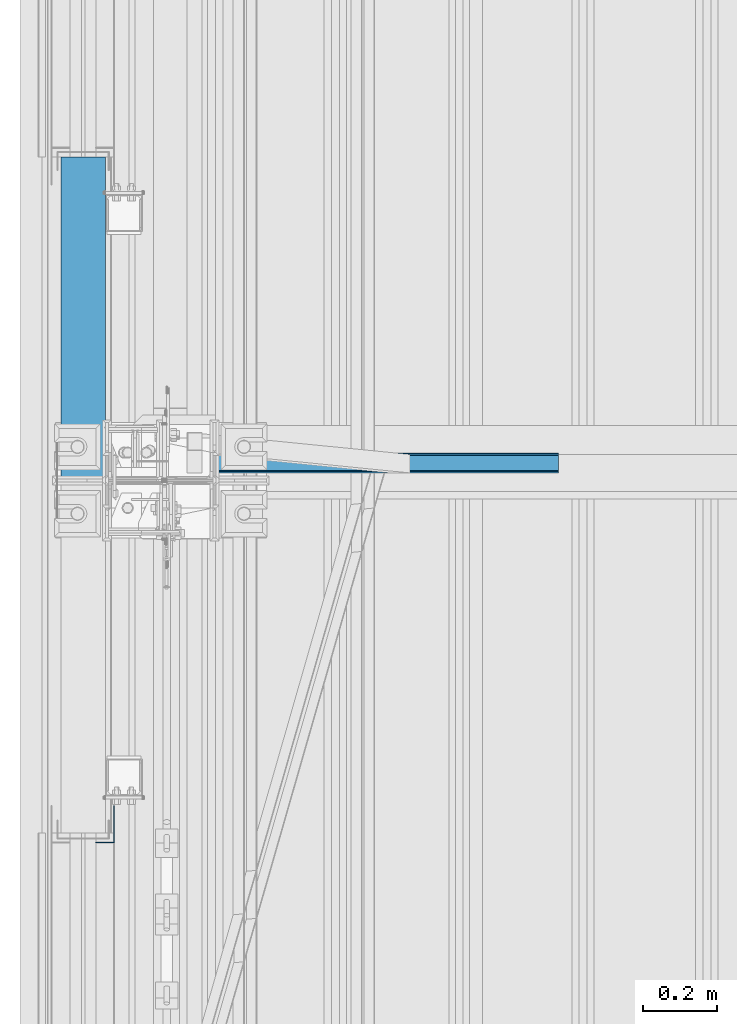
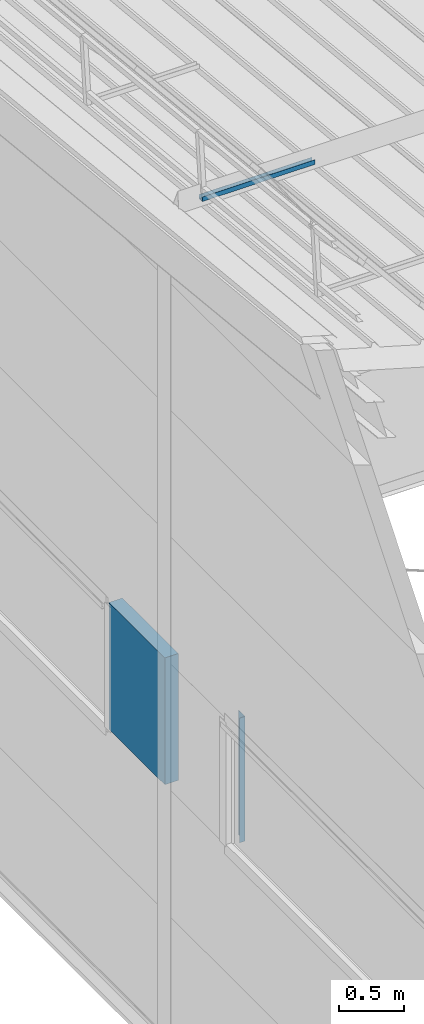
# One storey, part 47 of 709: 3 beams, 3 elements without a shape of their own.
"""IFC4 building model written with IfcOpenShell, lengths in millimetres."""

from ifc_helpers import new_model, si_unit, direction, frame, origin_with_axes, place, context, subcontext, project, spatial, line, indexed_curve, outline, extrude, material, element, aggregate, save


model = new_model("IFC4")

# Units and contexts
model_context = context("Model", 3, precision=0.2, world=origin_with_axes(), true_north=direction((0.0, 1.0)))
body_context = subcontext(model_context, "Body", "Model", "MODEL_VIEW")
ifc_project = project(units=[si_unit("LENGTHUNIT", "METRE", prefix="MILLI"), si_unit("AREAUNIT", "SQUARE_METRE"), si_unit("VOLUMEUNIT", "CUBIC_METRE"), si_unit("MASSUNIT", "GRAM", prefix="KILO"), si_unit("TIMEUNIT", "SECOND"), si_unit("PLANEANGLEUNIT", "RADIAN"), si_unit("SOLIDANGLEUNIT", "STERADIAN"), si_unit("THERMODYNAMICTEMPERATUREUNIT", "DEGREE_CELSIUS"), si_unit("LUMINOUSINTENSITYUNIT", "LUMEN")], contexts=[model_context])

# Site, building, storey
site_placement = place(None, origin_with_axes())
site = spatial("IfcSite", under=ifc_project, at=site_placement, CompositionType="ELEMENT")
building_placement = place(site_placement, origin_with_axes())
building = spatial("IfcBuilding", under=site, at=building_placement, Name="Undefined", CompositionType="ELEMENT")
storey_placement = place(building_placement, origin_with_axes())
storey = spatial("IfcBuildingStorey", under=building, at=storey_placement, Name="Undefined", CompositionType="ELEMENT", Elevation=0.0)

# Assembly, beam
assembly_1_placement = place(storey_placement, frame((220.0, 16546.76675, 8045.59294), z_axis=(0.0, 0.099503719, 0.9950371902), x_axis=(1.0, 0.0, 0.0)))
assembly_1 = element("IfcElementAssembly", 1, at=assembly_1_placement, inside=storey)
ifc_material_1 = material(Name="Steel_Undefined", Category="STEEL")
beam_1_placement = place(assembly_1_placement, origin_with_axes())
beam_1 = element("IfcBeam", 2, at=beam_1_placement, material=ifc_material_1, ObjectType="601", context=body_context, shape_type="SolidModel", body=[
    extrude(outline(indexed_curve([(-20.0, -25.0), (20.0, -25.0), (20.0, -22.5), (-17.5, -22.5), (-17.5, 22.5), (20.0, 22.5), (20.0, 25.0), (-20.0, 25.0)], segments=[line(1, 2, 3, 4, 5, 6, 7, 8, 1)])), frame((0.0, 0.0, 0.0), z_axis=(-1.0, 0.0, 0.0), x_axis=(0.0, 0.0, 1.0)), (0.0, 0.0, -1.0), 1000.0),
])
aggregate(assembly_1, [beam_1])

assembly_2_placement = place(storey_placement, frame((-60.0, 16510.0, 3275.0), z_axis=(0.0, 0.0, -1.0), x_axis=(0.0, 1.0, 0.0)))
assembly_2 = element("IfcElementAssembly", 3, at=assembly_2_placement, inside=storey)
ifc_material_2 = material(Name="Insulation", Category="Insulation")
beam_2_placement = place(assembly_2_placement, origin_with_axes())
beam_2 = element("IfcBeam", 4, at=beam_2_placement, material=ifc_material_2, ObjectType="P-140", context=body_context, shape_type="SolidModel", body=[
    extrude(outline(indexed_curve([(-595.0, -60.0), (595.0, -60.0), (595.0, 60.0), (-595.0, 60.0)], segments=[line(1, 2, 3, 4, 1)])), frame((0.0, 0.0, 0.0), z_axis=(-1.0, 0.0, 0.0), x_axis=(0.0, 0.0, 1.0)), (0.0, 0.0, -1.0), 860.0),
])
aggregate(assembly_2, [beam_2])

assembly_3_placement = place(storey_placement, frame((-1.0, 15525.0, 3870.0), z_axis=(1.0, 0.0, 0.0), x_axis=(0.0, 0.0, -1.0)))
assembly_3 = element("IfcElementAssembly", 5, at=assembly_3_placement, inside=storey)
beam_3_placement = place(assembly_3_placement, origin_with_axes())
beam_3 = element("IfcBeam", 6, at=beam_3_placement, material=ifc_material_1, context=body_context, shape_type="SolidModel", body=[
    extrude(outline(indexed_curve([(-25.0, -1.0), (25.0, -1.0), (25.0, 99.0), (23.0, 99.0), (23.0, 1.0), (-25.0, 1.0)], segments=[line(1, 2, 3, 4, 5, 6, 1)])), frame((0.0, 0.0, 0.0), z_axis=(-1.0, 0.0, 0.0), x_axis=(0.0, 0.0, 1.0)), (0.0, 0.0, -1.0), 1170.0),
])
aggregate(assembly_3, [beam_3])

save(model, "model.ifc")
